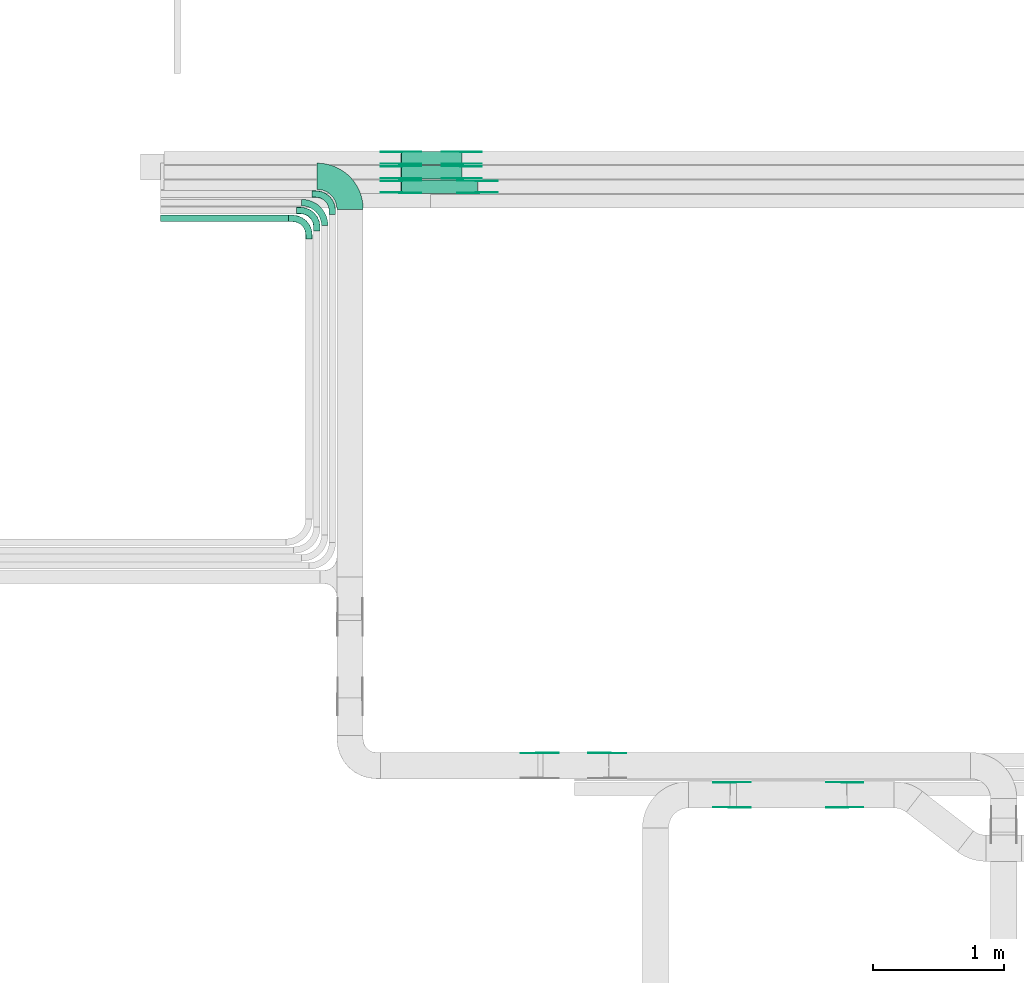
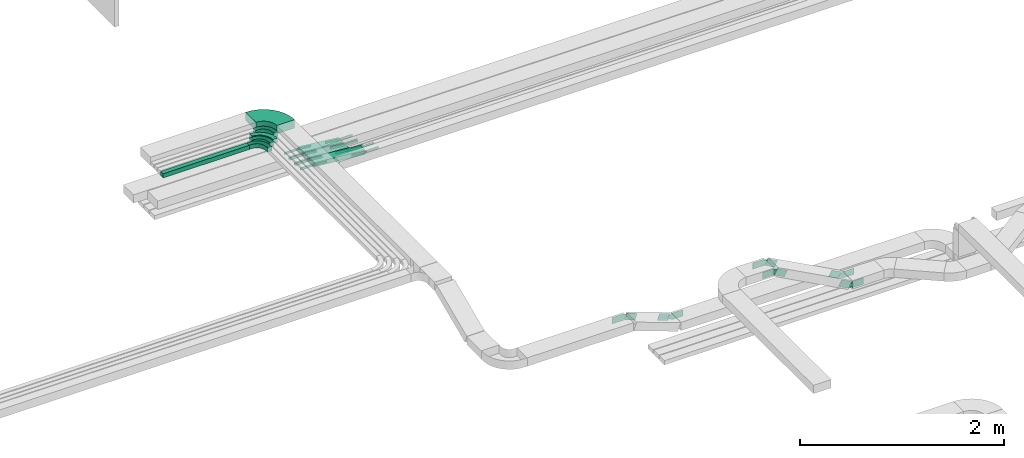
# One storey, part 4 of 23: 41 flow fittings, 4 flow segments.
"""IFC2X3 building model written with IfcOpenShell, lengths in millimetres."""

import ifcopenshell
import ifcopenshell.guid

model = None  # the IFC model being written
_history = None  # IfcOwnerHistory: only IFC2X3 demands one
_inside = {}  # id of a spatial element -> (the spatial element, [elements in it])
_under = {}  # id of a project, library or spatial element -> (it, [spatial elements below it])
_declared = {}  # id of a project -> (the project, [libraries it declares])
_typed = {}  # id of a type object -> (the type object, [elements of that type])
_made_of = {}  # id of a material, layer set ... -> (it, [elements and type objects made of it])


def new_model(schema):
    """Start an empty IFC model of exactly this schema.

    Asked for "IFC4X3", IfcOpenShell would pick the latest addendum, in which some entities
    have other attributes; the version numbers below select the first issue.
    IFC2X3 requires an IfcOwnerHistory on every rooted entity: one is made here for all.
    """
    global model, _history
    if schema == "IFC4X3":
        model = ifcopenshell.file(schema_version=(4, 3, 0, 0))
    else:
        model = ifcopenshell.file(schema=schema)
    _inside.clear()
    _under.clear()
    _declared.clear()
    _typed.clear()
    _made_of.clear()
    _history = None
    if model.schema == "IFC2X3":
        org = make("IfcOrganization", Name="unknown")
        user = make(
            "IfcPersonAndOrganization",
            ThePerson=make("IfcPerson", FamilyName="unknown"),
            TheOrganization=org,
        )
        app = make(
            "IfcApplication",
            ApplicationDeveloper=org,
            Version="unknown",
            ApplicationFullName="unknown",
            ApplicationIdentifier="unknown",
        )
        _history = make(
            "IfcOwnerHistory",
            OwningUser=user,
            OwningApplication=app,
            ChangeAction="ADDED",
            CreationDate=0,
        )
    return model


def make(cls, **values):
    """One entity of the class cls with the attributes given. An attribute that is None is left unset."""
    return model.create_entity(
        cls, **{name: value for name, value in values.items() if value is not None}
    )


def entity(cls, *values):
    """Any entity or typed value of the class cls, its attributes in the order of the schema. None: left unset."""
    e = model.create_entity(cls)
    for i, value in enumerate(values):
        if value is not None:
            e[i] = value
    return e


def rooted(cls, **values):
    """An entity with a GlobalId (a new one), such as an element, a storey or a relation."""
    return make(cls, GlobalId=ifcopenshell.guid.new(), OwnerHistory=_history, **values)


def si_unit(unit_type, name, prefix=None):
    """IfcSIUnit, for example si_unit("LENGTHUNIT", "METRE", prefix="MILLI")."""
    return make("IfcSIUnit", UnitType=unit_type, Prefix=prefix, Name=name)


def converted_unit(unit_type, name, factor, base, dimensions=None, offset=None):
    """IfcConversionBasedUnit, such as the inch: factor (a typed value) times the base unit."""
    return make(
        "IfcConversionBasedUnit"
        if offset is None
        else "IfcConversionBasedUnitWithOffset",
        ConversionOffset=offset,
        Dimensions=None
        if dimensions is None
        else entity("IfcDimensionalExponents", *dimensions),
        UnitType=unit_type,
        Name=name,
        ConversionFactor=make(
            "IfcMeasureWithUnit", ValueComponent=factor, UnitComponent=base
        ),
    )


def derived_unit(unit_type, elements):
    """IfcDerivedUnit: a product of units, each with its exponent."""
    return make(
        "IfcDerivedUnit",
        Elements=[
            make("IfcDerivedUnitElement", Unit=unit, Exponent=power)
            for unit, power in elements
        ],
        UnitType=unit_type,
    )


def assignment(units):
    """IfcUnitAssignment: the units of a project."""
    return None if units is None else make("IfcUnitAssignment", Units=units)


def point(xyz):
    """IfcCartesianPoint."""
    return None if xyz is None else make("IfcCartesianPoint", Coordinates=xyz)


def direction(xyz):
    """IfcDirection."""
    return None if xyz is None else make("IfcDirection", DirectionRatios=xyz)


def frame(location, z_axis=None, x_axis=None):
    """IfcAxis2Placement3D, a coordinate frame: its origin and axes. An axis left out is left unset."""
    return make(
        "IfcAxis2Placement3D",
        Location=point(location),
        Axis=direction(z_axis),
        RefDirection=direction(x_axis),
    )


def frame_2d(location, x_axis=None):
    """IfcAxis2Placement2D, a coordinate frame in the plane: its origin and x axis."""
    return make(
        "IfcAxis2Placement2D", Location=point(location), RefDirection=direction(x_axis)
    )


def origin():
    """The frame at (0, 0, 0) with its axes left unset."""
    return frame((0.0, 0.0, 0.0))


def origin_2d_with_axis():
    """The frame at (0, 0) in the plane with the x axis (1, 0) written out."""
    return frame_2d((0.0, 0.0), x_axis=(1.0, 0.0))


def place(relative_to, where):
    """IfcLocalPlacement: puts the frame where relative to a parent placement (None: the world)."""
    return make(
        "IfcLocalPlacement", PlacementRelTo=relative_to, RelativePlacement=where
    )


def context(
    kind, dimensions, precision=None, world=None, true_north=None, identifier=None
):
    """IfcGeometricRepresentationContext, for example the 3D "Model" context."""
    return make(
        "IfcGeometricRepresentationContext",
        ContextIdentifier=identifier,
        ContextType=kind,
        CoordinateSpaceDimension=dimensions,
        Precision=precision,
        WorldCoordinateSystem=world,
        TrueNorth=true_north,
    )


def subcontext(parent, identifier, kind, view, scale=None):
    """IfcGeometricRepresentationSubContext, for example "Body" below "Model"."""
    return make(
        "IfcGeometricRepresentationSubContext",
        ContextIdentifier=identifier,
        ContextType=kind,
        ParentContext=parent,
        TargetScale=scale,
        TargetView=view,
    )


def project(units=None, contexts=None):
    """IfcProject with its units and contexts."""
    return rooted(
        "IfcProject",
        Name="project",
        RepresentationContexts=contexts,
        UnitsInContext=assignment(units),
    )


def spatial(cls, under=None, at=None, **own):
    """A site, building, storey or space (cls), placed at a placement, below another one or the project."""
    s = rooted(cls, ObjectPlacement=at, **own)
    if under is not None:
        _under.setdefault(under.id(), (under, []))[1].append(s)
    return s


def polyline(points):
    """IfcPolyline through the points."""
    return make("IfcPolyline", Points=[point(p) for p in points])


def circle_curve(where, radius):
    """IfcCircle in the frame where."""
    return make("IfcCircle", Position=where, Radius=radius)


def parameter(value):
    """IfcParameterValue: where a trimmed curve begins or ends, as a parameter of its basis curve."""
    return model.create_entity("IfcParameterValue", value)


def trimmed(basis, trim1, trim2, sense, master):
    """IfcTrimmedCurve: the piece of a basis curve between two trims."""
    return make(
        "IfcTrimmedCurve",
        BasisCurve=basis,
        Trim1=trim1,
        Trim2=trim2,
        SenseAgreement=sense,
        MasterRepresentation=master,
    )


def segment(curve, same_sense, transition):
    """IfcCompositeCurveSegment."""
    return make(
        "IfcCompositeCurveSegment",
        Transition=transition,
        SameSense=same_sense,
        ParentCurve=curve,
    )


def composite_curve(segments, self_intersect=None):
    """IfcCompositeCurve: segments joined end to end."""
    return make("IfcCompositeCurve", Segments=segments, SelfIntersect=self_intersect)


def profile(cls, at=None, kind="AREA", **sizes):
    """A parametric profile (cls). Its sizes go by their IFC names, for example OverallWidth=200.0."""
    return make(cls, ProfileType=kind, Position=at, **sizes)


def rectangle(**sizes):
    """IfcRectangleProfileDef."""
    return profile("IfcRectangleProfileDef", **sizes)


def outline(outer, holes=None, kind="AREA"):
    """IfcArbitraryClosedProfileDef: a profile drawn as a closed curve; with holes, ...WithVoids."""
    if holes is None:
        return make("IfcArbitraryClosedProfileDef", ProfileType=kind, OuterCurve=outer)
    return make(
        "IfcArbitraryProfileDefWithVoids",
        ProfileType=kind,
        OuterCurve=outer,
        InnerCurves=holes,
    )


def extrude(swept, where, along, depth):
    """IfcExtrudedAreaSolid: the profile swept, set in the frame where, extruded along a direction by depth."""
    return make(
        "IfcExtrudedAreaSolid",
        SweptArea=swept,
        Position=where,
        ExtrudedDirection=direction(along),
        Depth=depth,
    )


def faces_of(points, faces, orient=None, outer=None):
    """IfcFace entities. A face is a list of loops; a loop is a list of indices into points, from 0.

    orient and outer hold one flag for each loop. By default every Orientation is true, the
    first loop of a face is its IfcFaceOuterBound and the others are IfcFaceBound.
    """
    made = []
    for i, loops in enumerate(faces):
        bounds = []
        for j, loop in enumerate(loops):
            is_outer = j == 0 if outer is None else outer[i][j]
            bounds.append(
                make(
                    "IfcFaceOuterBound" if is_outer else "IfcFaceBound",
                    Bound=make("IfcPolyLoop", Polygon=[points[k] for k in loop]),
                    Orientation=True if orient is None else orient[i][j],
                )
            )
        made.append(make("IfcFace", Bounds=bounds))
    return made


def faceted_brep(points, faces, orient=None, outer=None, voids=None):
    """IfcFacetedBrep: a solid bounded by flat faces; with voids (closed shells), ...WithVoids."""
    shared = [point(p) for p in points]
    hull = make("IfcClosedShell", CfsFaces=faces_of(shared, faces, orient, outer))
    if voids is None:
        return make("IfcFacetedBrep", Outer=hull)
    return make(
        "IfcFacetedBrepWithVoids",
        Outer=hull,
        Voids=[
            make(cls, CfsFaces=faces_of(shared, fs, o, b)) for cls, fs, o, b in voids
        ],
    )


def shape(context_of_items, identifier, shape_type, items):
    """IfcShapeRepresentation: the items that make up one representation, for example the "Body"."""
    return make(
        "IfcShapeRepresentation",
        ContextOfItems=context_of_items,
        RepresentationIdentifier=identifier,
        RepresentationType=shape_type,
        Items=items,
    )


def source(mapping_origin, context_of_items, identifier, shape_type, items):
    """IfcRepresentationMap: a shape defined once, which mapped items show again and again."""
    return make(
        "IfcRepresentationMap",
        MappingOrigin=mapping_origin,
        MappedRepresentation=shape(context_of_items, identifier, shape_type, items),
    )


def transform(
    local_origin,
    x_axis=None,
    y_axis=None,
    z_axis=None,
    scale=None,
    scale2=None,
    scale3=None,
    uniform=True,
):
    """IfcCartesianTransformationOperator3D, or its non-uniform kind. x_axis, y_axis, z_axis: its Axis1, 2, 3."""
    if uniform:
        return make(
            "IfcCartesianTransformationOperator3D",
            Axis1=direction(x_axis),
            Axis2=direction(y_axis),
            LocalOrigin=point(local_origin),
            Scale=scale,
            Axis3=direction(z_axis),
        )
    return make(
        "IfcCartesianTransformationOperator3DnonUniform",
        Axis1=direction(x_axis),
        Axis2=direction(y_axis),
        LocalOrigin=point(local_origin),
        Scale=scale,
        Axis3=direction(z_axis),
        Scale2=scale2,
        Scale3=scale3,
    )


def mapped(mapping_source, mapping_target):
    """IfcMappedItem: shows the shape of a source again, moved by a transform."""
    return make(
        "IfcMappedItem", MappingSource=mapping_source, MappingTarget=mapping_target
    )


def material(Name=None, Category=None):
    """IfcMaterial."""
    return make("IfcMaterial", Name=Name, Category=Category)


def made_of(thing, what):
    """Note that an element or type object is made of a material, layer set ...; save() writes the relation."""
    if what is not None:
        _made_of.setdefault(what.id(), (what, []))[1].append(thing)
    return thing


def type_object(cls, material=None, **own):
    """A type object (cls), such as IfcWallType, which elements share."""
    return made_of(rooted(cls, **own), material)


def type_shapes(of_type, sources):
    """Give a type object the sources (RepresentationMaps) that its elements show as mapped items."""
    of_type.RepresentationMaps = sources


def element(
    cls,
    number,
    at=None,
    inside=None,
    cuts=None,
    type_object=None,
    material=None,
    context=None,
    identifier="Body",
    shape_type=None,
    held_by="IfcProductDefinitionShape",
    body=None,
    shapes=None,
    **own,
):
    """One element of the class cls, such as IfcWall. Its Tag is "e" and its number.

    at: its placement. inside: the storey or other place that contains it. cuts: it is an
    opening in that element (IfcRelVoidsElement). A single representation is given by context,
    identifier, shape_type and body (its items); several are given by shapes. held_by: the class
    of the entity that holds the representations. save() writes the other relations.
    """
    e = rooted(cls, Tag="e%d" % number, ObjectPlacement=at, **own)
    if body is not None:
        shapes = [shape(context, identifier, shape_type, body)]
    if shapes is not None:
        e.Representation = make(held_by, Representations=shapes)
    if inside is not None:
        _inside.setdefault(inside.id(), (inside, []))[1].append(e)
    if cuts is not None:
        rooted(
            "IfcRelVoidsElement", RelatingBuildingElement=cuts, RelatedOpeningElement=e
        )
    if type_object is not None:
        _typed.setdefault(type_object.id(), (type_object, []))[1].append(e)
    return made_of(e, material)


def aggregate(whole, parts):
    """IfcRelAggregates: a whole, such as a stair, and the parts it consists of."""
    return rooted("IfcRelAggregates", RelatingObject=whole, RelatedObjects=parts)


def save(model, path):
    """Write the relations noted so far, then the file.

    IfcRelAggregates (storeys below a building ...), IfcRelContainedInSpatialStructure (elements
    in a storey), IfcRelDefinesByType, IfcRelAssociatesMaterial and IfcRelDeclares: one each for
    every whole, place, type object, material and project.
    """
    for whole, parts in _under.values():
        aggregate(whole, parts)
    for where, things in _inside.values():
        rooted(
            "IfcRelContainedInSpatialStructure",
            RelatedElements=things,
            RelatingStructure=where,
        )
    for kind, things in _typed.values():
        rooted("IfcRelDefinesByType", RelatedObjects=things, RelatingType=kind)
    for what, things in _made_of.values():
        rooted("IfcRelAssociatesMaterial", RelatedObjects=things, RelatingMaterial=what)
    for by, libraries in _declared.values():
        rooted("IfcRelDeclares", RelatingContext=by, RelatedDefinitions=libraries)
    model.write(path)


model = new_model("IFC2X3")

# Units and contexts
model_context = context("Model", 3, precision=0.01, world=origin(), true_north=direction((6.12303176911189e-17, 1.0)))
body_context = subcontext(model_context, "Body", "Model", "MODEL_VIEW")
ifc_project = project(units=[si_unit("LENGTHUNIT", "METRE", prefix="MILLI"), si_unit("AREAUNIT", "SQUARE_METRE"), si_unit("VOLUMEUNIT", "CUBIC_METRE"), converted_unit("PLANEANGLEUNIT", "DEGREE", entity("IfcRatioMeasure", 0.0174532925199433), si_unit("PLANEANGLEUNIT", "RADIAN"), dimensions=[0, 0, 0, 0, 0, 0, 0]), si_unit("MASSUNIT", "GRAM", prefix="KILO"), derived_unit("MASSDENSITYUNIT", [(si_unit("MASSUNIT", "GRAM", prefix="KILO"), 1), (si_unit("LENGTHUNIT", "METRE"), -3)]), derived_unit("MOMENTOFINERTIAUNIT", [(si_unit("LENGTHUNIT", "METRE"), 4)]), si_unit("TIMEUNIT", "SECOND"), si_unit("FREQUENCYUNIT", "HERTZ"), si_unit("THERMODYNAMICTEMPERATUREUNIT", "DEGREE_CELSIUS"), derived_unit("THERMALTRANSMITTANCEUNIT", [(si_unit("MASSUNIT", "GRAM", prefix="KILO"), 1), (si_unit("THERMODYNAMICTEMPERATUREUNIT", "KELVIN"), -1), (si_unit("TIMEUNIT", "SECOND"), -3)]), derived_unit("VOLUMETRICFLOWRATEUNIT", [(si_unit("LENGTHUNIT", "METRE"), 3), (si_unit("TIMEUNIT", "SECOND"), -1)]), derived_unit("MASSFLOWRATEUNIT", [(si_unit("MASSUNIT", "GRAM", prefix="KILO"), 1), (si_unit("TIMEUNIT", "SECOND"), -1)]), derived_unit("ROTATIONALFREQUENCYUNIT", [(si_unit("TIMEUNIT", "SECOND"), -1)]), si_unit("ELECTRICCURRENTUNIT", "AMPERE"), si_unit("ELECTRICVOLTAGEUNIT", "VOLT"), si_unit("POWERUNIT", "WATT"), si_unit("FORCEUNIT", "NEWTON", prefix="KILO"), si_unit("ILLUMINANCEUNIT", "LUX"), si_unit("LUMINOUSFLUXUNIT", "LUMEN"), si_unit("LUMINOUSINTENSITYUNIT", "CANDELA"), derived_unit("USERDEFINED", [(si_unit("MASSUNIT", "GRAM", prefix="KILO"), -1), (si_unit("LENGTHUNIT", "METRE"), -2), (si_unit("TIMEUNIT", "SECOND"), 3), (si_unit("LUMINOUSFLUXUNIT", "LUMEN"), 1)]), derived_unit("LINEARVELOCITYUNIT", [(si_unit("LENGTHUNIT", "METRE"), 1), (si_unit("TIMEUNIT", "SECOND"), -1)]), si_unit("PRESSUREUNIT", "PASCAL"), derived_unit("USERDEFINED", [(si_unit("LENGTHUNIT", "METRE"), -2), (si_unit("MASSUNIT", "GRAM", prefix="KILO"), 1), (si_unit("TIMEUNIT", "SECOND"), -2)]), derived_unit("LINEARFORCEUNIT", [(si_unit("MASSUNIT", "GRAM", prefix="KILO"), 1), (si_unit("LENGTHUNIT", "METRE"), 1), (si_unit("TIMEUNIT", "SECOND"), -2), (si_unit("LENGTHUNIT", "METRE"), -1)]), derived_unit("PLANARFORCEUNIT", [(si_unit("MASSUNIT", "GRAM", prefix="KILO"), 1), (si_unit("LENGTHUNIT", "METRE"), 1), (si_unit("TIMEUNIT", "SECOND"), -2), (si_unit("LENGTHUNIT", "METRE"), -2)])], contexts=[model_context])

# Site, building, storey
site_placement = place(None, origin())
site = spatial("IfcSite", under=ifc_project, at=site_placement, CompositionType="ELEMENT")
building_placement = place(site_placement, origin())
building = spatial("IfcBuilding", under=site, at=building_placement, CompositionType="ELEMENT")
storey_placement = place(building_placement, frame((0.0, 0.0, 24000.0)))
storey = spatial("IfcBuildingStorey", under=building, at=storey_placement, CompositionType="ELEMENT", Elevation=24000.0)

# Flow segments
cable_carrier_segment_type = type_object("IfcCableCarrierSegmentType", PredefinedType="CABLETRAYSEGMENT")
flow_segment_1_placement = place(storey_placement, frame((16371.73, 14262.41, 3340.0)))
element("IfcFlowSegment", 1, at=flow_segment_1_placement, inside=storey, type_object=cable_carrier_segment_type, context=body_context, shape_type="SweptSolid", body=[
    extrude(rectangle(XDim=973.920225446046, YDim=50.0000000000016, at=origin_2d_with_axis()), frame((486.96, 25.0, 0.0)), (0.0, 0.0, 1.0), 49.9999999999973),
])
for number, where in (
    (2, (18199.27, 14697.82, 2650.42)),
    (3, (18199.27, 14587.82, 2650.42)),
):
    element("IfcFlowSegment", number, at=place(storey_placement, frame(where)), inside=storey, type_object=cable_carrier_segment_type, context=body_context, shape_type="SweptSolid", body=[
        extrude(rectangle(XDim=49.9999999999976, YDim=99.9999999999989, at=frame_2d((0.0, 0.0), x_axis=(0.0, 1.0))), frame((2.68, 50.0, 74.31), z_axis=(0.994236268075928, 0.0, -0.10721120856726), x_axis=(0.0, 1.0, 0.0)), (0.0, 0.0, 1.0), 461.251037015058),
    ])
flow_segment_2_placement = place(storey_placement, frame((18199.5, 14477.82, 2650.28)))
element("IfcFlowSegment", 4, at=flow_segment_2_placement, inside=storey, type_object=cable_carrier_segment_type, context=body_context, shape_type="SweptSolid", body=[
    extrude(rectangle(XDim=49.9999999999984, YDim=99.9999999999989, at=frame_2d((0.0, 0.0), x_axis=(0.0, 1.0))), frame((2.13, 50.0, 74.53), z_axis=(0.996350977668468, 0.0, -0.0853506256514122), x_axis=(0.0, 1.0, 0.0)), (0.0, 0.0, 1.0), 581.339094760914),
])

# Flow fittings
ifc_material_1 = material()
cable_carrier_fitting_type_1 = type_object("IfcCableCarrierFittingType", Name="470_DKC_S5_CPO 45 horizontal angle:-", PredefinedType="NOTDEFINED", material=ifc_material_1)
shared_shape_1 = source(origin(), body_context, "Body", "Brep", [
    faceted_brep([(-155.0, -24.2, -24.2), (-155.0, 24.2, -24.2), (-155.0, 24.2, 25.0), (-155.0, 25.0, 25.0), (-155.0, 25.0, -25.0), (-155.0, -25.0, -25.0), (-155.0, -25.0, 25.0), (-155.0, -24.2, 25.0), (-125.0, -25.0, -25.0), (-125.0, -25.0, 25.0), (-86.18, -19.89, 25.0), (-50.0, -4.9, 25.0), (-18.93, 18.93, 25.0), (4.9, 50.0, 25.0), (19.89, 86.18, 25.0), (25.0, 125.0, 25.0), (25.0, 155.0, 25.0), (24.2, 155.0, 25.0), (24.2, 125.0, 25.0), (19.12, 86.38, 25.0), (4.21, 50.4, 25.0), (-19.5, 19.5, 25.0), (-50.4, -4.21, 25.0), (-86.38, -19.12, 25.0), (-125.0, -24.2, 25.0), (-125.0, 24.2, 25.0), (-93.85, 29.13, 25.0), (-65.75, 43.45, 25.0), (-43.45, 65.75, 25.0), (-29.13, 93.85, 25.0), (-24.2, 125.0, 25.0), (-24.2, 155.0, 25.0), (-25.0, 155.0, 25.0), (-25.0, 125.0, 25.0), (-29.89, 94.1, 25.0), (-44.1, 66.22, 25.0), (-66.22, 44.1, 25.0), (-94.1, 29.89, 25.0), (-125.0, 25.0, 25.0), (-125.0, -24.2, -24.2), (-86.38, -19.12, -24.2), (-50.4, -4.21, -24.2), (-19.5, 19.5, -24.2), (4.21, 50.4, -24.2), (19.12, 86.38, -24.2), (24.2, 125.0, -24.2), (24.2, 155.0, -24.2), (-24.2, 155.0, -24.2), (-24.2, 125.0, -24.2), (-29.13, 93.85, -24.2), (-43.45, 65.75, -24.2), (-65.75, 43.45, -24.2), (-93.85, 29.13, -24.2), (-125.0, 24.2, -24.2), (-125.0, 25.0, -25.0), (-94.1, 29.89, -25.0), (-66.22, 44.1, -25.0), (-44.1, 66.22, -25.0), (-29.89, 94.1, -25.0), (-25.0, 125.0, -25.0), (-25.0, 155.0, -25.0), (25.0, 155.0, -25.0), (25.0, 125.0, -25.0), (19.89, 86.18, -25.0), (4.9, 50.0, -25.0), (-18.93, 18.93, -25.0), (-50.0, -4.9, -25.0), (-86.18, -19.89, -25.0)], [[[0, 1, 2, 3, 4, 5, 6, 7]], [[6, 5, 8, 9]], [[7, 6, 9, 10, 11, 12, 13, 14, 15, 16, 17, 18, 19, 20, 21, 22, 23, 24]], [[3, 2, 25, 26, 27, 28, 29, 30, 31, 32, 33, 34, 35, 36, 37, 38]], [[0, 7, 24, 39]], [[1, 0, 39, 40, 41, 42, 43, 44, 45, 46, 47, 48, 49, 50, 51, 52, 53]], [[2, 1, 53, 25]], [[4, 3, 38, 54]], [[4, 54, 55, 56, 57, 58, 59, 60, 61, 62, 63, 64, 65, 66, 67, 8, 5]], [[10, 9, 8, 67]], [[11, 10, 67, 66]], [[12, 11, 66, 65]], [[63, 62, 15, 14]], [[13, 64, 63, 14]], [[64, 13, 12, 65]], [[40, 39, 24, 23]], [[41, 40, 23, 22]], [[41, 22, 21, 42]], [[19, 18, 45, 44]], [[19, 44, 43, 20]], [[42, 21, 20, 43]], [[26, 25, 53, 52]], [[27, 26, 52, 51]], [[51, 50, 28, 27]], [[29, 28, 50, 49]], [[29, 49, 48, 30]], [[55, 54, 38, 37]], [[56, 55, 37, 36]], [[36, 35, 57, 56]], [[58, 57, 35, 34]], [[59, 58, 34, 33]], [[60, 32, 31, 47, 46, 17, 16, 61]], [[15, 62, 61, 16]], [[45, 18, 17, 46]], [[30, 48, 47, 31]], [[59, 33, 32, 60]]]),
])
type_shapes(cable_carrier_fitting_type_1, [shared_shape_1])
for number, where, z_axis, x_axis, name in (
    (5, (17500.65, 14287.41, 3365.0), (0.0, 0.0, 1.0), (0.0, 1.0, 0.0), "470_DKC_S5_45 horizontal angle"),
    (6, (17560.65, 14347.41, 3365.0), (0.0, 0.0, 1.0), (0.0, 1.0, 0.0), "470_DKC_S5_45 horizontal angle"),
    (7, (17678.15, 14472.74, 3365.0), (0.0, 0.0, 1.0), (0.0, 1.0, 0.0), "470_DKC_S5_45 horizontal angle"),
):
    element("IfcFlowFitting", number, at=place(storey_placement, frame(where, z_axis=z_axis, x_axis=x_axis)), inside=storey, type_object=cable_carrier_fitting_type_1, material=ifc_material_1, Name=name, ObjectType="470_DKC_S5_CPO 45 horizontal angle:-", context=body_context, shape_type="MappedRepresentation", body=[
        mapped(shared_shape_1, transform((0.0, 0.0, 0.0), scale=1.0)),
    ])
cable_carrier_fitting_type_2 = type_object("IfcCableCarrierFittingType", Name="470_DKC_S5_Variable Angle Elbow 0-45:-", PredefinedType="NOTDEFINED", material=ifc_material_1)
shared_shape_2 = source(origin(), body_context, "Body", "SweptSolid", [
    extrude(outline(composite_curve([segment(polyline([(-125.75, -225.25), (-124.75, -225.25)]), True, "CONTINUOUS"), segment(trimmed(circle_curve(frame_2d((-124.75, 124.75), x_axis=(0.0, -1.0)), 350.0), [parameter(0.0)], [parameter(90.0000000000001)], True, "PARAMETER"), True, "CONTINUOUS"), segment(polyline([(225.25, 124.75), (225.25, 125.75)]), True, "CONTINUOUS"), segment(polyline([(225.25, 125.75), (25.25, 125.75)]), True, "CONTINUOUS"), segment(polyline([(25.25, 125.75), (25.25, 124.75)]), True, "CONTINUOUS"), segment(trimmed(circle_curve(frame_2d((-124.75, 124.75), x_axis=(0.0, -1.0)), 150.0), [parameter(0.0)], [parameter(90.0000000000001)], True, "PARAMETER"), False, "CONTINUOUS"), segment(polyline([(-124.75, -25.25), (-125.75, -25.25)]), True, "CONTINUOUS"), segment(polyline([(-125.75, -25.25), (-125.75, -225.25)]), True, "CONTINUOUS")], self_intersect=False)), frame((-125.25, 125.25, -50.0)), (0.0, 0.0, 1.0), 100.0),
])
type_shapes(cable_carrier_fitting_type_2, [shared_shape_2])
flow_fitting_1_placement = place(storey_placement, frame((17813.15, 14607.74, 3390.0), z_axis=(0.0, 0.0, 1.0), x_axis=(0.0, 1.0, 0.0)))
element("IfcFlowFitting", 8, at=flow_fitting_1_placement, inside=storey, type_object=cable_carrier_fitting_type_2, material=ifc_material_1, Name="470_DKC_S5_Variable Angle Elbow 0-45:-", ObjectType="470_DKC_S5_Variable Angle Elbow 0-45:-", context=body_context, shape_type="MappedRepresentation", body=[
    mapped(shared_shape_2, transform((0.0, 0.0, 0.0), scale=1.0)),
])
ifc_material_2 = material(Name="G")
cable_carrier_fitting_type_3 = type_object("IfcCableCarrierFittingType", PredefinedType="NOTDEFINED", material=ifc_material_2)
shared_shape_3 = source(origin(), body_context, "Body", "SweptSolid", [
    extrude(outline(composite_curve([segment(trimmed(circle_curve(frame_2d((-44.59, 0.0), x_axis=(1.0, 0.0)), 12.5), [parameter(90.0000000000007)], [parameter(270.0)], True, "PARAMETER"), True, "CONTINUOUS"), segment(polyline([(-44.59, -12.5), (-33.09, -12.5)]), True, "CONTINUOUS"), segment(polyline([(-33.09, -12.5), (-31.23, -14.5)]), True, "CONTINUOUS"), segment(polyline([(-31.23, -14.5), (108.91, -14.5)]), True, "CONTINUOUS"), segment(polyline([(108.91, -14.5), (108.91, 14.5)]), True, "CONTINUOUS"), segment(polyline([(108.91, 14.5), (-31.23, 14.5)]), True, "CONTINUOUS"), segment(polyline([(-31.23, 14.5), (-33.09, 12.5)]), True, "CONTINUOUS"), segment(polyline([(-33.09, 12.5), (-44.59, 12.5)]), True, "CONTINUOUS")], self_intersect=False)), frame((44.59, 0.0, 0.0), z_axis=(0.0, 0.0, -1.0), x_axis=(1.0, 0.0, 0.0)), (0.0, 0.0, -1.0), 2.0),
])
type_shapes(cable_carrier_fitting_type_3, [shared_shape_3])
flow_fitting_2_placement = place(storey_placement, frame((18199.4, 14793.28, 2725.0), z_axis=(0.0, 1.0, 0.0), x_axis=(0.994236268075924, 0.0, -0.107211208567296)))
element("IfcFlowFitting", 9, at=flow_fitting_2_placement, inside=storey, type_object=cable_carrier_fitting_type_3, material=ifc_material_2, context=body_context, shape_type="MappedRepresentation", body=[
    mapped(shared_shape_3, transform((0.0, 0.0, 0.0), scale=1.0)),
])
cable_carrier_fitting_type_4 = type_object("IfcCableCarrierFittingType", PredefinedType="NOTDEFINED", material=ifc_material_2)
type_shapes(cable_carrier_fitting_type_4, [shared_shape_3])
flow_fitting_3_placement = place(storey_placement, frame((18199.4, 14704.36, 2725.0), z_axis=(0.0, -1.0, 0.0), x_axis=(-1.0, 0.0, 0.0)))
element("IfcFlowFitting", 10, at=flow_fitting_3_placement, inside=storey, type_object=cable_carrier_fitting_type_4, material=ifc_material_2, context=body_context, shape_type="MappedRepresentation", body=[
    mapped(shared_shape_3, transform((0.0, 0.0, 0.0), scale=1.0)),
])
flow_fitting_4_placement = place(storey_placement, frame((18663.08, 14793.28, 2675.0), z_axis=(0.0, 1.0, 0.0), x_axis=(-0.994236268075924, 0.0, 0.107211208567296)))
element("IfcFlowFitting", 11, at=flow_fitting_4_placement, inside=storey, type_object=cable_carrier_fitting_type_3, material=ifc_material_2, context=body_context, shape_type="MappedRepresentation", body=[
    mapped(shared_shape_3, transform((0.0, 0.0, 0.0), scale=1.0)),
])
flow_fitting_5_placement = place(storey_placement, frame((18663.08, 14704.36, 2675.0), z_axis=(0.0, -1.0, 0.0), x_axis=(1.0, 0.0, 0.0)))
element("IfcFlowFitting", 12, at=flow_fitting_5_placement, inside=storey, type_object=cable_carrier_fitting_type_4, material=ifc_material_2, context=body_context, shape_type="MappedRepresentation", body=[
    mapped(shared_shape_3, transform((0.0, 0.0, 0.0), scale=1.0)),
])
flow_fitting_6_placement = place(storey_placement, frame((18199.4, 14683.28, 2725.0), z_axis=(0.0, 1.0, 0.0), x_axis=(0.994236268075924, 0.0, -0.107211208567296)))
element("IfcFlowFitting", 13, at=flow_fitting_6_placement, inside=storey, type_object=cable_carrier_fitting_type_3, material=ifc_material_2, context=body_context, shape_type="MappedRepresentation", body=[
    mapped(shared_shape_3, transform((0.0, 0.0, 0.0), scale=1.0)),
])
flow_fitting_7_placement = place(storey_placement, frame((18199.4, 14594.36, 2725.0), z_axis=(0.0, -1.0, 0.0), x_axis=(-1.0, 0.0, 0.0)))
element("IfcFlowFitting", 14, at=flow_fitting_7_placement, inside=storey, type_object=cable_carrier_fitting_type_4, material=ifc_material_2, context=body_context, shape_type="MappedRepresentation", body=[
    mapped(shared_shape_3, transform((0.0, 0.0, 0.0), scale=1.0)),
])
flow_fitting_8_placement = place(storey_placement, frame((18663.08, 14683.28, 2675.0), z_axis=(0.0, 1.0, 0.0), x_axis=(-0.994236268075924, 0.0, 0.107211208567296)))
element("IfcFlowFitting", 15, at=flow_fitting_8_placement, inside=storey, type_object=cable_carrier_fitting_type_3, material=ifc_material_2, context=body_context, shape_type="MappedRepresentation", body=[
    mapped(shared_shape_3, transform((0.0, 0.0, 0.0), scale=1.0)),
])
flow_fitting_9_placement = place(storey_placement, frame((18663.08, 14594.36, 2675.0), z_axis=(0.0, -1.0, 0.0), x_axis=(1.0, 0.0, 0.0)))
element("IfcFlowFitting", 16, at=flow_fitting_9_placement, inside=storey, type_object=cable_carrier_fitting_type_4, material=ifc_material_2, context=body_context, shape_type="MappedRepresentation", body=[
    mapped(shared_shape_3, transform((0.0, 0.0, 0.0), scale=1.0)),
])
flow_fitting_10_placement = place(storey_placement, frame((18199.4, 14573.28, 2725.0), z_axis=(0.0, 1.0, 0.0), x_axis=(0.996350977668465, 0.0, -0.0853506256514489)))
element("IfcFlowFitting", 17, at=flow_fitting_10_placement, inside=storey, type_object=cable_carrier_fitting_type_3, material=ifc_material_2, context=body_context, shape_type="MappedRepresentation", body=[
    mapped(shared_shape_3, transform((0.0, 0.0, 0.0), scale=1.0)),
])
flow_fitting_11_placement = place(storey_placement, frame((18199.4, 14484.36, 2725.0), z_axis=(0.0, -1.0, 0.0), x_axis=(-1.0, 0.0, 0.0)))
element("IfcFlowFitting", 18, at=flow_fitting_11_placement, inside=storey, type_object=cable_carrier_fitting_type_4, material=ifc_material_2, context=body_context, shape_type="MappedRepresentation", body=[
    mapped(shared_shape_3, transform((0.0, 0.0, 0.0), scale=1.0)),
])
flow_fitting_12_placement = place(storey_placement, frame((18783.08, 14573.28, 2675.0), z_axis=(0.0, 1.0, 0.0), x_axis=(-0.996350977668465, 0.0, 0.0853506256514489)))
element("IfcFlowFitting", 19, at=flow_fitting_12_placement, inside=storey, type_object=cable_carrier_fitting_type_3, material=ifc_material_2, context=body_context, shape_type="MappedRepresentation", body=[
    mapped(shared_shape_3, transform((0.0, 0.0, 0.0), scale=1.0)),
])
flow_fitting_13_placement = place(storey_placement, frame((18783.08, 14484.36, 2675.0), z_axis=(0.0, -1.0, 0.0), x_axis=(1.0, 0.0, 0.0)))
element("IfcFlowFitting", 20, at=flow_fitting_13_placement, inside=storey, type_object=cable_carrier_fitting_type_4, material=ifc_material_2, context=body_context, shape_type="MappedRepresentation", body=[
    mapped(shared_shape_3, transform((0.0, 0.0, 0.0), scale=1.0)),
])
cable_carrier_fitting_type_5 = type_object("IfcCableCarrierFittingType", PredefinedType="NOTDEFINED", material=ifc_material_2)
shared_shape_4 = source(origin(), body_context, "Body", "SweptSolid", [
    extrude(outline(composite_curve([segment(trimmed(circle_curve(frame_2d((-44.59, 0.0), x_axis=(1.0, 0.0)), 12.5), [parameter(90.0000000000007)], [parameter(270.0)], True, "PARAMETER"), True, "CONTINUOUS"), segment(polyline([(-44.59, -12.5), (-33.09, -12.5)]), True, "CONTINUOUS"), segment(polyline([(-33.09, -12.5), (-31.23, -14.5)]), True, "CONTINUOUS"), segment(polyline([(-31.23, -14.5), (108.91, -14.5)]), True, "CONTINUOUS"), segment(polyline([(108.91, -14.5), (108.91, 14.5)]), True, "CONTINUOUS"), segment(polyline([(108.91, 14.5), (-31.23, 14.5)]), True, "CONTINUOUS"), segment(polyline([(-31.23, 14.5), (-33.09, 12.5)]), True, "CONTINUOUS"), segment(polyline([(-33.09, 12.5), (-44.59, 12.5)]), True, "CONTINUOUS")], self_intersect=False)), frame((44.59, 0.0, 0.0)), (0.0, 0.0, 1.0), 2.0),
])
type_shapes(cable_carrier_fitting_type_5, [shared_shape_4])
flow_fitting_14_placement = place(storey_placement, frame((18199.4, 14702.36, 2725.0), z_axis=(0.0, -1.0, 0.0), x_axis=(0.994236268075924, 0.0, -0.107211208567296)))
element("IfcFlowFitting", 21, at=flow_fitting_14_placement, inside=storey, type_object=cable_carrier_fitting_type_5, material=ifc_material_2, context=body_context, shape_type="MappedRepresentation", body=[
    mapped(shared_shape_4, transform((0.0, 0.0, 0.0), scale=1.0)),
])
cable_carrier_fitting_type_6 = type_object("IfcCableCarrierFittingType", PredefinedType="NOTDEFINED", material=ifc_material_2)
type_shapes(cable_carrier_fitting_type_6, [shared_shape_4])
flow_fitting_15_placement = place(storey_placement, frame((18199.4, 14791.28, 2725.0), z_axis=(0.0, 1.0, 0.0), x_axis=(-1.0, 0.0, 0.0)))
element("IfcFlowFitting", 22, at=flow_fitting_15_placement, inside=storey, type_object=cable_carrier_fitting_type_6, material=ifc_material_2, context=body_context, shape_type="MappedRepresentation", body=[
    mapped(shared_shape_4, transform((0.0, 0.0, 0.0), scale=1.0)),
])
flow_fitting_16_placement = place(storey_placement, frame((18663.08, 14702.36, 2675.0), z_axis=(0.0, -1.0, 0.0), x_axis=(-0.994236268075924, 0.0, 0.107211208567296)))
element("IfcFlowFitting", 23, at=flow_fitting_16_placement, inside=storey, type_object=cable_carrier_fitting_type_5, material=ifc_material_2, context=body_context, shape_type="MappedRepresentation", body=[
    mapped(shared_shape_4, transform((0.0, 0.0, 0.0), scale=1.0)),
])
flow_fitting_17_placement = place(storey_placement, frame((18663.08, 14791.28, 2675.0), z_axis=(0.0, 1.0, 0.0), x_axis=(1.0, 0.0, 0.0)))
element("IfcFlowFitting", 24, at=flow_fitting_17_placement, inside=storey, type_object=cable_carrier_fitting_type_6, material=ifc_material_2, context=body_context, shape_type="MappedRepresentation", body=[
    mapped(shared_shape_4, transform((0.0, 0.0, 0.0), scale=1.0)),
])
flow_fitting_18_placement = place(storey_placement, frame((18199.4, 14592.36, 2725.0), z_axis=(0.0, -1.0, 0.0), x_axis=(0.994236268075924, 0.0, -0.107211208567296)))
element("IfcFlowFitting", 25, at=flow_fitting_18_placement, inside=storey, type_object=cable_carrier_fitting_type_5, material=ifc_material_2, context=body_context, shape_type="MappedRepresentation", body=[
    mapped(shared_shape_4, transform((0.0, 0.0, 0.0), scale=1.0)),
])
flow_fitting_19_placement = place(storey_placement, frame((18199.4, 14681.28, 2725.0), z_axis=(0.0, 1.0, 0.0), x_axis=(-1.0, 0.0, 0.0)))
element("IfcFlowFitting", 26, at=flow_fitting_19_placement, inside=storey, type_object=cable_carrier_fitting_type_6, material=ifc_material_2, context=body_context, shape_type="MappedRepresentation", body=[
    mapped(shared_shape_4, transform((0.0, 0.0, 0.0), scale=1.0)),
])
flow_fitting_20_placement = place(storey_placement, frame((18663.08, 14592.36, 2675.0), z_axis=(0.0, -1.0, 0.0), x_axis=(-0.994236268075924, 0.0, 0.107211208567296)))
element("IfcFlowFitting", 27, at=flow_fitting_20_placement, inside=storey, type_object=cable_carrier_fitting_type_5, material=ifc_material_2, context=body_context, shape_type="MappedRepresentation", body=[
    mapped(shared_shape_4, transform((0.0, 0.0, 0.0), scale=1.0)),
])
flow_fitting_21_placement = place(storey_placement, frame((18663.08, 14681.28, 2675.0), z_axis=(0.0, 1.0, 0.0), x_axis=(1.0, 0.0, 0.0)))
element("IfcFlowFitting", 28, at=flow_fitting_21_placement, inside=storey, type_object=cable_carrier_fitting_type_6, material=ifc_material_2, context=body_context, shape_type="MappedRepresentation", body=[
    mapped(shared_shape_4, transform((0.0, 0.0, 0.0), scale=1.0)),
])
flow_fitting_22_placement = place(storey_placement, frame((18199.4, 14482.36, 2725.0), z_axis=(0.0, -1.0, 0.0), x_axis=(0.996350977668465, 0.0, -0.0853506256514489)))
element("IfcFlowFitting", 29, at=flow_fitting_22_placement, inside=storey, type_object=cable_carrier_fitting_type_5, material=ifc_material_2, context=body_context, shape_type="MappedRepresentation", body=[
    mapped(shared_shape_4, transform((0.0, 0.0, 0.0), scale=1.0)),
])
flow_fitting_23_placement = place(storey_placement, frame((18199.4, 14571.28, 2725.0), z_axis=(0.0, 1.0, 0.0), x_axis=(-1.0, 0.0, 0.0)))
element("IfcFlowFitting", 30, at=flow_fitting_23_placement, inside=storey, type_object=cable_carrier_fitting_type_6, material=ifc_material_2, context=body_context, shape_type="MappedRepresentation", body=[
    mapped(shared_shape_4, transform((0.0, 0.0, 0.0), scale=1.0)),
])
flow_fitting_24_placement = place(storey_placement, frame((18783.08, 14482.36, 2675.0), z_axis=(0.0, -1.0, 0.0), x_axis=(-0.996350977668465, 0.0, 0.0853506256514489)))
element("IfcFlowFitting", 31, at=flow_fitting_24_placement, inside=storey, type_object=cable_carrier_fitting_type_5, material=ifc_material_2, context=body_context, shape_type="MappedRepresentation", body=[
    mapped(shared_shape_4, transform((0.0, 0.0, 0.0), scale=1.0)),
])
flow_fitting_25_placement = place(storey_placement, frame((18783.08, 14571.28, 2675.0), z_axis=(0.0, 1.0, 0.0), x_axis=(1.0, 0.0, 0.0)))
element("IfcFlowFitting", 32, at=flow_fitting_25_placement, inside=storey, type_object=cable_carrier_fitting_type_6, material=ifc_material_2, context=body_context, shape_type="MappedRepresentation", body=[
    mapped(shared_shape_4, transform((0.0, 0.0, 0.0), scale=1.0)),
])
cable_carrier_fitting_type_7 = type_object("IfcCableCarrierFittingType", PredefinedType="NOTDEFINED", material=ifc_material_2)
shared_shape_5 = source(origin(), body_context, "Body", "SweptSolid", [
    extrude(outline(composite_curve([segment(trimmed(circle_curve(frame_2d((-41.47, 0.0), x_axis=(1.0, 0.0)), 25.0), [parameter(90.0000000000007)], [parameter(270.0)], True, "PARAMETER"), True, "CONTINUOUS"), segment(polyline([(-41.47, -25.0), (-29.97, -25.0)]), True, "CONTINUOUS"), segment(polyline([(-29.97, -25.0), (-28.1, -38.5)]), True, "CONTINUOUS"), segment(polyline([(-28.1, -38.5), (99.53, -38.5)]), True, "CONTINUOUS"), segment(polyline([(99.53, -38.5), (99.53, 38.5)]), True, "CONTINUOUS"), segment(polyline([(99.53, 38.5), (-28.1, 38.5)]), True, "CONTINUOUS"), segment(polyline([(-28.1, 38.5), (-29.97, 25.0)]), True, "CONTINUOUS"), segment(polyline([(-29.97, 25.0), (-41.47, 25.0)]), True, "CONTINUOUS")], self_intersect=False)), frame((41.47, 0.0, 0.0), z_axis=(0.0, 0.0, -1.0), x_axis=(1.0, 0.0, 0.0)), (0.0, 0.0, -1.0), 2.0),
])
type_shapes(cable_carrier_fitting_type_7, [shared_shape_5])
for number, where, z_axis, x_axis in (
    (33, (19771.73, 10220.4, 2940.0), (0.0, 1.0, 0.0), (-0.942059127858493, 0.0, 0.335446865566657)),
    (34, (19253.08, 10220.4, 3124.68), (0.0, 1.0, 0.0), (0.942059127858493, 0.0, -0.335446865566657)),
    (35, (20716.87, 9998.12, 3401.74), (0.0, 1.0, 0.0), (0.881037228424637, 0.0, -0.473046934383719)),
):
    element("IfcFlowFitting", number, at=place(storey_placement, frame(where, z_axis=z_axis, x_axis=x_axis)), inside=storey, type_object=cable_carrier_fitting_type_7, material=ifc_material_2, context=body_context, shape_type="MappedRepresentation", body=[
        mapped(shared_shape_5, transform((0.0, 0.0, 0.0), scale=1.0)),
    ])
cable_carrier_fitting_type_8 = type_object("IfcCableCarrierFittingType", PredefinedType="NOTDEFINED", material=ifc_material_2)
type_shapes(cable_carrier_fitting_type_8, [shared_shape_5])
flow_fitting_26_placement = place(storey_placement, frame((20716.87, 9809.2, 3401.74), z_axis=(0.0, -1.0, 0.0), x_axis=(-1.0, 0.0, 0.0)))
element("IfcFlowFitting", 36, at=flow_fitting_26_placement, inside=storey, type_object=cable_carrier_fitting_type_8, material=ifc_material_2, context=body_context, shape_type="MappedRepresentation", body=[
    mapped(shared_shape_5, transform((0.0, 0.0, 0.0), scale=1.0)),
])
flow_fitting_27_placement = place(storey_placement, frame((21576.85, 9998.12, 2940.0), z_axis=(0.0, 1.0, 0.0), x_axis=(-0.881037228424637, 0.0, 0.473046934383719)))
element("IfcFlowFitting", 37, at=flow_fitting_27_placement, inside=storey, type_object=cable_carrier_fitting_type_7, material=ifc_material_2, context=body_context, shape_type="MappedRepresentation", body=[
    mapped(shared_shape_5, transform((0.0, 0.0, 0.0), scale=1.0)),
])
flow_fitting_28_placement = place(storey_placement, frame((21576.85, 9809.2, 2940.0), z_axis=(0.0, -1.0, 0.0), x_axis=(1.0, 0.0, 0.0)))
element("IfcFlowFitting", 38, at=flow_fitting_28_placement, inside=storey, type_object=cable_carrier_fitting_type_8, material=ifc_material_2, context=body_context, shape_type="MappedRepresentation", body=[
    mapped(shared_shape_5, transform((0.0, 0.0, 0.0), scale=1.0)),
])
cable_carrier_fitting_type_9 = type_object("IfcCableCarrierFittingType", PredefinedType="NOTDEFINED", material=ifc_material_2)
shared_shape_6 = source(origin(), body_context, "Body", "SweptSolid", [
    extrude(outline(composite_curve([segment(trimmed(circle_curve(frame_2d((-41.47, 0.0), x_axis=(1.0, 0.0)), 25.0), [parameter(90.0000000000007)], [parameter(270.0)], True, "PARAMETER"), True, "CONTINUOUS"), segment(polyline([(-41.47, -25.0), (-29.97, -25.0)]), True, "CONTINUOUS"), segment(polyline([(-29.97, -25.0), (-28.1, -38.5)]), True, "CONTINUOUS"), segment(polyline([(-28.1, -38.5), (99.53, -38.5)]), True, "CONTINUOUS"), segment(polyline([(99.53, -38.5), (99.53, 38.5)]), True, "CONTINUOUS"), segment(polyline([(99.53, 38.5), (-28.1, 38.5)]), True, "CONTINUOUS"), segment(polyline([(-28.1, 38.5), (-29.97, 25.0)]), True, "CONTINUOUS"), segment(polyline([(-29.97, 25.0), (-41.47, 25.0)]), True, "CONTINUOUS")], self_intersect=False)), frame((41.47, 0.0, 0.0)), (0.0, 0.0, 1.0), 2.0),
])
type_shapes(cable_carrier_fitting_type_9, [shared_shape_6])
for number, where, z_axis, x_axis in (
    (39, (19771.73, 10218.4, 2940.0), (0.0, 1.0, 0.0), (1.0, 0.0, 0.0)),
    (40, (19253.08, 10218.4, 3124.68), (0.0, 1.0, 0.0), (-1.0, 0.0, 0.0)),
):
    element("IfcFlowFitting", number, at=place(storey_placement, frame(where, z_axis=z_axis, x_axis=x_axis)), inside=storey, type_object=cable_carrier_fitting_type_9, material=ifc_material_2, context=body_context, shape_type="MappedRepresentation", body=[
        mapped(shared_shape_6, transform((0.0, 0.0, 0.0), scale=1.0)),
    ])
cable_carrier_fitting_type_10 = type_object("IfcCableCarrierFittingType", PredefinedType="NOTDEFINED", material=ifc_material_2)
type_shapes(cable_carrier_fitting_type_10, [shared_shape_6])
flow_fitting_29_placement = place(storey_placement, frame((20716.87, 9807.2, 3401.74), z_axis=(0.0, -1.0, 0.0), x_axis=(0.881037228424637, 0.0, -0.473046934383719)))
element("IfcFlowFitting", 41, at=flow_fitting_29_placement, inside=storey, type_object=cable_carrier_fitting_type_10, material=ifc_material_2, context=body_context, shape_type="MappedRepresentation", body=[
    mapped(shared_shape_6, transform((0.0, 0.0, 0.0), scale=1.0)),
])
flow_fitting_30_placement = place(storey_placement, frame((20716.87, 9996.12, 3401.74), z_axis=(0.0, 1.0, 0.0), x_axis=(-1.0, 0.0, 0.0)))
element("IfcFlowFitting", 42, at=flow_fitting_30_placement, inside=storey, type_object=cable_carrier_fitting_type_9, material=ifc_material_2, context=body_context, shape_type="MappedRepresentation", body=[
    mapped(shared_shape_6, transform((0.0, 0.0, 0.0), scale=1.0)),
])
flow_fitting_31_placement = place(storey_placement, frame((21576.85, 9807.2, 2940.0), z_axis=(0.0, -1.0, 0.0), x_axis=(-0.881037228424637, 0.0, 0.473046934383719)))
element("IfcFlowFitting", 43, at=flow_fitting_31_placement, inside=storey, type_object=cable_carrier_fitting_type_10, material=ifc_material_2, context=body_context, shape_type="MappedRepresentation", body=[
    mapped(shared_shape_6, transform((0.0, 0.0, 0.0), scale=1.0)),
])
flow_fitting_32_placement = place(storey_placement, frame((21576.85, 9996.12, 2940.0), z_axis=(0.0, 1.0, 0.0), x_axis=(1.0, 0.0, 0.0)))
element("IfcFlowFitting", 44, at=flow_fitting_32_placement, inside=storey, type_object=cable_carrier_fitting_type_9, material=ifc_material_2, context=body_context, shape_type="MappedRepresentation", body=[
    mapped(shared_shape_6, transform((0.0, 0.0, 0.0), scale=1.0)),
])
cable_carrier_fitting_type_11 = type_object("IfcCableCarrierFittingType", Name="470_DKC_S5_Variable Angle Elbow 0-45:-", PredefinedType="NOTDEFINED", material=ifc_material_1)
shared_shape_7 = source(origin(), body_context, "Body", "SweptSolid", [
    extrude(outline(composite_curve([segment(polyline([(-88.25, -112.75), (-87.25, -112.75)]), True, "CONTINUOUS"), segment(trimmed(circle_curve(frame_2d((-87.25, 87.25), x_axis=(0.0, -1.0)), 200.0), [parameter(0.0)], [parameter(90.0000000000001)], True, "PARAMETER"), True, "CONTINUOUS"), segment(polyline([(112.75, 87.25), (112.75, 88.25)]), True, "CONTINUOUS"), segment(polyline([(112.75, 88.25), (62.75, 88.25)]), True, "CONTINUOUS"), segment(polyline([(62.75, 88.25), (62.75, 87.25)]), True, "CONTINUOUS"), segment(trimmed(circle_curve(frame_2d((-87.25, 87.25), x_axis=(0.0, -1.0)), 150.0), [parameter(0.0)], [parameter(90.0000000000001)], True, "PARAMETER"), False, "CONTINUOUS"), segment(polyline([(-87.25, -62.75), (-88.25, -62.75)]), True, "CONTINUOUS"), segment(polyline([(-88.25, -62.75), (-88.25, -112.75)]), True, "CONTINUOUS")], self_intersect=False)), frame((-87.75, 87.75, -25.0)), (0.0, 0.0, 1.0), 50.0000000000007),
])
type_shapes(cable_carrier_fitting_type_11, [shared_shape_7])
flow_fitting_33_placement = place(storey_placement, frame((17620.65, 14407.41, 3365.0), z_axis=(0.0, 0.0, 1.0), x_axis=(0.0, 1.0, 0.0)))
element("IfcFlowFitting", 45, at=flow_fitting_33_placement, inside=storey, type_object=cable_carrier_fitting_type_11, material=ifc_material_1, Name="470_DKC_S5_Variable Angle Elbow 0-45:-", ObjectType="470_DKC_S5_Variable Angle Elbow 0-45:-", context=body_context, shape_type="MappedRepresentation", body=[
    mapped(shared_shape_7, transform((0.0, 0.0, 0.0), scale=1.0)),
])

save(model, "model.ifc")
